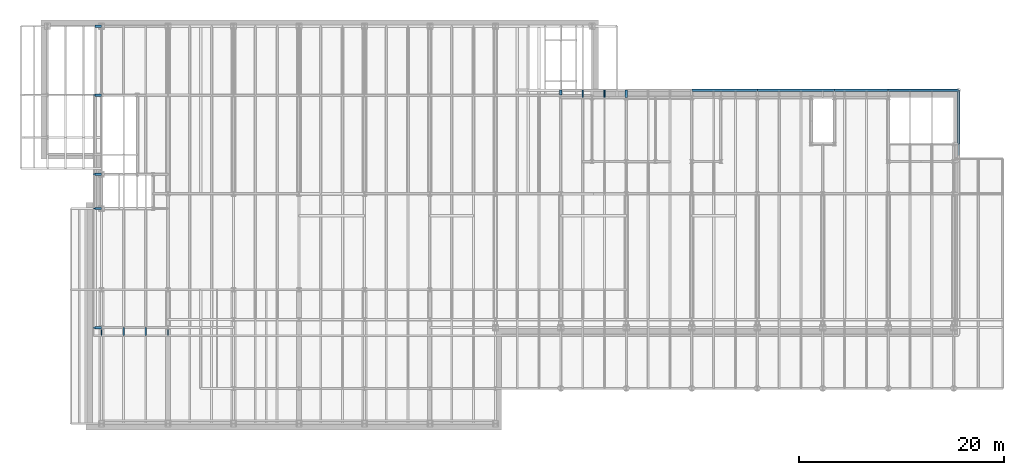
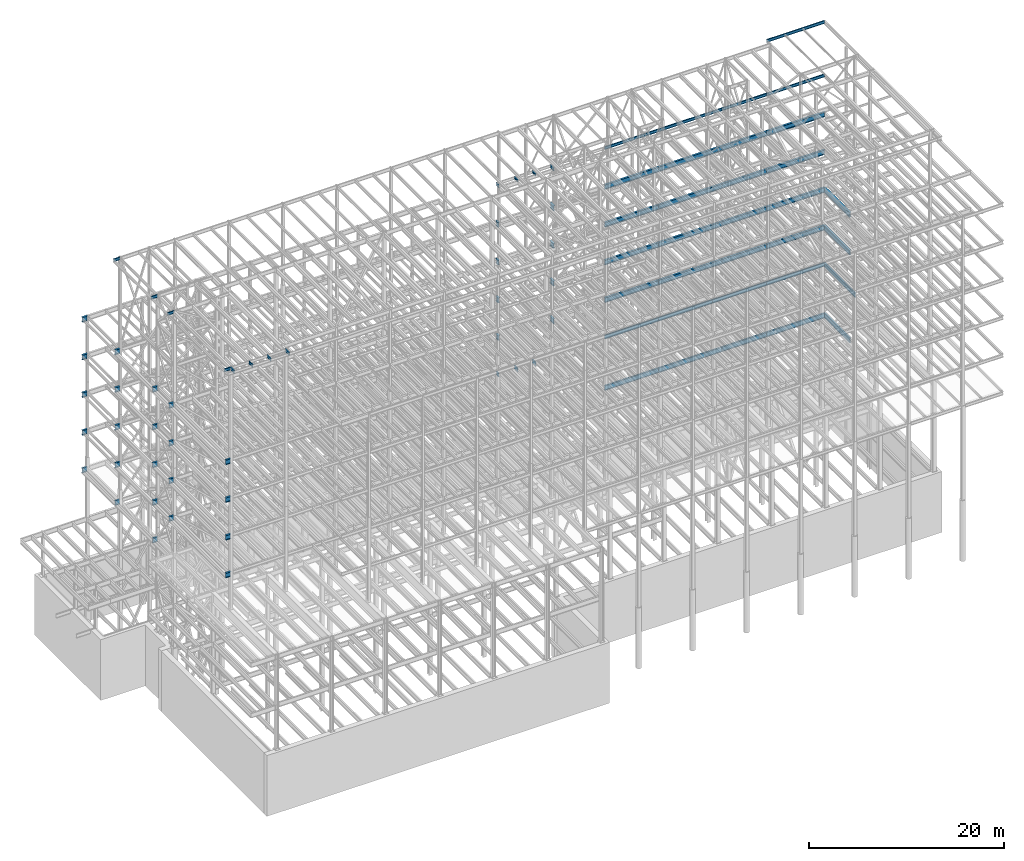
# One storey, part 148 of 150: 79 beams.
"""IFC2X3 building model written with IfcOpenShell, lengths in millimetres."""

from ifc_helpers import new_model, si_unit, frame, origin_with_axes, origin_2d_with_axis, place, context, subcontext, project, spatial, i_section, extrude, material, type_object, element, save


model = new_model("IFC2X3")

# Units and contexts
model_context = context("Model", 3, precision=1e-05, world=origin_with_axes())
body_context = subcontext(model_context, "Body", "Model", "MODEL_VIEW")
ifc_project = project(units=[si_unit("LENGTHUNIT", "METRE", prefix="MILLI"), si_unit("AREAUNIT", "SQUARE_METRE"), si_unit("VOLUMEUNIT", "CUBIC_METRE"), si_unit("MASSUNIT", "GRAM", prefix="KILO"), si_unit("TIMEUNIT", "SECOND"), si_unit("PLANEANGLEUNIT", "RADIAN"), si_unit("SOLIDANGLEUNIT", "STERADIAN"), si_unit("THERMODYNAMICTEMPERATUREUNIT", "DEGREE_CELSIUS"), si_unit("LUMINOUSINTENSITYUNIT", "LUMEN")], contexts=[model_context])

# Site, building, storey
site_placement = place(None, origin_with_axes())
site = spatial("IfcSite", under=ifc_project, at=site_placement, CompositionType="ELEMENT")
building_placement = place(site_placement, origin_with_axes())
building = spatial("IfcBuilding", under=site, at=building_placement, Name="Undefined", CompositionType="ELEMENT")
storey_placement = place(building_placement, origin_with_axes())
storey = spatial("IfcBuildingStorey", under=building, at=storey_placement, Name="Undefined", CompositionType="ELEMENT", Elevation=0.0)

# Beams
ifc_material = material(Name="STEEL/A992")
beam_type_1 = type_object("IfcBeamType", Name="W18X35", PredefinedType="NOTDEFINED")
for number, where, z_axis, x_axis, name in (
    (1, (54457.6, 31877.0, 35359.975), (0.0, 0.0, 1.0), (0.0, 1.0, 0.0), "BEAM"),
    (2, (52324.0, 31877.0, 35359.975), (0.0, 0.0, 1.0), (0.0, 1.0, 0.0), "BEAM"),
):
    element("IfcBeam", number, at=place(storey_placement, frame(where, z_axis=z_axis, x_axis=x_axis)), inside=storey, type_object=beam_type_1, material=ifc_material, Name=name, ObjectType="W18X35", context=body_context, shape_type="SweptSolid", body=[
        extrude(i_section(OverallWidth=152.4, OverallDepth=450.85, WebThickness=7.9375, FlangeThickness=10.795, FilletRadius=17.78, at=origin_2d_with_axis()), frame((736.599999999991, 0.0, 0.0), z_axis=(-1.0, 0.0, 0.0), x_axis=(0.0, -1.0, 0.0)), (0.0, 0.0, 1.0), 736.599999999991),
    ])
for number, where, z_axis, x_axis, name in (
    (3, (75793.6, 32613.6, 35359.975), (0.0, 0.0, 1.0), (1.0, 0.0, 0.0), "BEAM"),
    (4, (69392.8, 32613.6, 35359.975), (0.0, 0.0, 1.0), (1.0, 0.0, 0.0), "BEAM"),
):
    element("IfcBeam", number, at=place(storey_placement, frame(where, z_axis=z_axis, x_axis=x_axis)), inside=storey, type_object=beam_type_1, material=ifc_material, Name=name, ObjectType="W18X35", context=body_context, shape_type="SweptSolid", body=[
        extrude(i_section(OverallWidth=152.4, OverallDepth=450.85, WebThickness=7.9375, FlangeThickness=10.795, FilletRadius=17.78, at=origin_2d_with_axis()), frame((6400.80000000001, 0.0, 0.0), z_axis=(-1.0, 0.0, 0.0), x_axis=(0.0, -1.0, 0.0)), (0.0, 0.0, 1.0), 6400.8),
    ])
beam_1_placement = place(storey_placement, frame((62992.0, 32613.6, 35359.975), z_axis=(0.0, 0.0, 1.0), x_axis=(1.0, 0.0, 0.0)))
element("IfcBeam", 5, at=beam_1_placement, inside=storey, type_object=beam_type_1, material=ifc_material, Name="BEAM", ObjectType="W18X35", context=body_context, shape_type="SweptSolid", body=[
    extrude(i_section(OverallWidth=152.4, OverallDepth=450.85, WebThickness=7.9375, FlangeThickness=10.795, FilletRadius=17.78, at=origin_2d_with_axis()), frame((6400.80000000001, 0.0, 0.0), z_axis=(-1.0, 0.0, 0.0), x_axis=(0.0, -1.0, 0.0)), (0.0, 0.0, 1.0), 6400.79999999999),
])
beam_2_placement = place(storey_placement, frame((50190.4, 32131.0, 35359.975), z_axis=(0.0, 0.0, 1.0), x_axis=(0.0, 1.0, 0.0)))
element("IfcBeam", 6, at=beam_2_placement, inside=storey, type_object=beam_type_1, material=ifc_material, Name="BEAM", ObjectType="W18X35", context=body_context, shape_type="SweptSolid", body=[
    extrude(i_section(OverallWidth=152.4, OverallDepth=450.85, WebThickness=7.9375, FlangeThickness=10.795, FilletRadius=17.78, at=origin_2d_with_axis()), frame((482.600000000006, 0.0, 0.0), z_axis=(-1.0, 0.0, 0.0), x_axis=(0.0, -1.0, 0.0)), (0.0, 0.0, 1.0), 482.599999999999),
])
beam_3_placement = place(storey_placement, frame((82194.4, 32613.6, 35359.975), z_axis=(0.0, 0.0, 1.0), x_axis=(1.0, 0.0, 0.0)))
element("IfcBeam", 7, at=beam_3_placement, inside=storey, type_object=beam_type_1, material=ifc_material, Name="BEAM", ObjectType="W18X35", context=body_context, shape_type="SweptSolid", body=[
    extrude(i_section(OverallWidth=152.4, OverallDepth=450.85, WebThickness=7.9375, FlangeThickness=10.795, FilletRadius=17.78, at=origin_2d_with_axis()), frame((6883.40000000001, 0.0, 0.0), z_axis=(-1.0, 0.0, 0.0), x_axis=(0.0, -1.0, 0.0)), (0.0, 0.0, 1.0), 6883.40000000001),
])
beam_type_2 = type_object("IfcBeamType", Name="W24X68", PredefinedType="NOTDEFINED")
for number, where, z_axis, x_axis, name in (
    (8, (4673.6, 38862.0, 54181.375), (0.0, 0.0, 1.0), (1.0, 0.0, 0.0), "BEAM"),
    (9, (4673.6, 24384.0, 54181.375), (0.0, 0.0, 1.0), (1.0, 0.0, 0.0), "BEAM"),
    (10, (4673.6, 32131.0, 54181.375), (0.0, 0.0, 1.0), (1.0, 0.0, 0.0), "BEAM"),
):
    element("IfcBeam", number, at=place(storey_placement, frame(where, z_axis=z_axis, x_axis=x_axis)), inside=storey, type_object=beam_type_2, material=ifc_material, Name=name, ObjectType="W24X68", context=body_context, shape_type="SweptSolid", body=[
        extrude(i_section(OverallWidth=227.838, OverallDepth=603.25, WebThickness=11.1125, FlangeThickness=14.859, FilletRadius=23.2409, at=origin_2d_with_axis()), frame((609.599999999999, 0.0, 0.0), z_axis=(-1.0, 0.0, 0.0), x_axis=(0.0, -1.0, 0.0)), (0.0, 0.0, 1.0), 609.599999999999),
    ])
beam_4_placement = place(storey_placement, frame((50190.4, 32131.0, 54181.375), z_axis=(0.0, 0.0, 1.0), x_axis=(0.0, 1.0, 0.0)))
element("IfcBeam", 11, at=beam_4_placement, inside=storey, type_object=beam_type_2, material=ifc_material, Name="BEAM", ObjectType="W24X68", context=body_context, shape_type="SweptSolid", body=[
    extrude(i_section(OverallWidth=227.838, OverallDepth=603.25, WebThickness=11.1125, FlangeThickness=14.859, FilletRadius=23.2409, at=origin_2d_with_axis()), frame((482.600000000006, 0.0, 0.0), z_axis=(-1.0, 0.0, 0.0), x_axis=(0.0, -1.0, 0.0)), (0.0, 0.0, 1.0), 482.599999999999),
])
beam_5_placement = place(storey_placement, frame((56591.2, 31877.0, 54181.375), z_axis=(0.0, 0.0, 1.0), x_axis=(0.0, 1.0, 0.0)))
element("IfcBeam", 12, at=beam_5_placement, inside=storey, type_object=beam_type_2, material=ifc_material, Name="BEAM", ObjectType="W24X68", context=body_context, shape_type="SweptSolid", body=[
    extrude(i_section(OverallWidth=227.838, OverallDepth=603.25, WebThickness=11.1125, FlangeThickness=14.859, FilletRadius=23.2409, at=origin_2d_with_axis()), frame((736.599999999991, 0.0, 0.0), z_axis=(-1.0, 0.0, 0.0), x_axis=(0.0, -1.0, 0.0)), (0.0, 0.0, 1.0), 736.599999999991),
])
beam_6_placement = place(storey_placement, frame((62992.0, 32613.6, 54181.375), z_axis=(0.0, 0.0, 1.0), x_axis=(1.0, 0.0, 0.0)))
element("IfcBeam", 13, at=beam_6_placement, inside=storey, type_object=beam_type_2, material=ifc_material, Name="BEAM", ObjectType="W24X68", context=body_context, shape_type="SweptSolid", body=[
    extrude(i_section(OverallWidth=227.838, OverallDepth=603.25, WebThickness=11.1125, FlangeThickness=14.859, FilletRadius=23.2409, at=origin_2d_with_axis()), frame((6400.79935992001, 0.0, 0.0), z_axis=(-1.0, 0.0, 0.0), x_axis=(0.0, -1.0, 0.0)), (0.0, 0.0, 1.0), 6400.79935991999),
])
beam_7_placement = place(storey_placement, frame((69392.8, 32613.6, 54181.375), z_axis=(0.0, 0.0, 1.0), x_axis=(1.0, 0.0, 0.0)))
element("IfcBeam", 14, at=beam_7_placement, inside=storey, type_object=beam_type_2, material=ifc_material, Name="BEAM", ObjectType="W24X68", context=body_context, shape_type="SweptSolid", body=[
    extrude(i_section(OverallWidth=227.838, OverallDepth=603.25, WebThickness=11.1125, FlangeThickness=14.859, FilletRadius=23.2409, at=origin_2d_with_axis()), frame((7531.10000000001, 0.0, 0.0), z_axis=(-1.0, 0.0, 0.0), x_axis=(0.0, -1.0, 0.0)), (0.0, 0.0, 1.0), 7531.10000000001),
])
beam_8_placement = place(storey_placement, frame((82194.4, 32613.6, 54181.375), z_axis=(0.0, 0.0, 1.0), x_axis=(1.0, 0.0, 0.0)))
element("IfcBeam", 15, at=beam_8_placement, inside=storey, type_object=beam_type_2, material=ifc_material, Name="BEAM", ObjectType="W24X68", context=body_context, shape_type="SweptSolid", body=[
    extrude(i_section(OverallWidth=227.838, OverallDepth=603.25, WebThickness=11.1125, FlangeThickness=14.859, FilletRadius=23.2409, at=origin_2d_with_axis()), frame((6883.40000000001, 0.0, 0.0), z_axis=(-1.0, 0.0, 0.0), x_axis=(0.0, -1.0, 0.0)), (0.0, 0.0, 1.0), 6883.40000000001),
])
beam_9_placement = place(storey_placement, frame((76923.9, 32613.6, 54181.375), z_axis=(0.0, 0.0, 1.0), x_axis=(1.0, 0.0, 0.0)))
element("IfcBeam", 16, at=beam_9_placement, inside=storey, type_object=beam_type_2, material=ifc_material, Name="BEAM", ObjectType="W24X68", context=body_context, shape_type="SweptSolid", body=[
    extrude(i_section(OverallWidth=227.838, OverallDepth=603.25, WebThickness=11.1125, FlangeThickness=14.859, FilletRadius=23.2409, at=origin_2d_with_axis()), frame((5270.5, 0.0, 0.0), z_axis=(-1.0, 0.0, 0.0), x_axis=(0.0, -1.0, 0.0)), (0.0, 0.0, 1.0), 5270.5),
])
for number, where, z_axis, x_axis, name in (
    (17, (4673.6, 9398.0, 54181.375), (0.0, 0.0, 1.0), (1.0, 0.0, 0.0), "BEAM"),
    (18, (4673.6, 21043.9, 54181.375), (0.0, 0.0, 1.0), (1.0, 0.0, 0.0), "BEAM"),
    (19, (4673.6, 38862.0, 49456.975), (0.0, 0.0, 1.0), (1.0, 0.0, 0.0), "BEAM"),
    (20, (4673.6, 24384.0, 49456.975), (0.0, 0.0, 1.0), (1.0, 0.0, 0.0), "BEAM"),
    (21, (4673.6, 32131.0, 49456.975), (0.0, 0.0, 1.0), (1.0, 0.0, 0.0), "BEAM"),
):
    element("IfcBeam", number, at=place(storey_placement, frame(where, z_axis=z_axis, x_axis=x_axis)), inside=storey, type_object=beam_type_2, material=ifc_material, Name=name, ObjectType="W24X68", context=body_context, shape_type="SweptSolid", body=[
        extrude(i_section(OverallWidth=227.838, OverallDepth=603.25, WebThickness=11.1125, FlangeThickness=14.859, FilletRadius=23.2409, at=origin_2d_with_axis()), frame((609.599999999999, 0.0, 0.0), z_axis=(-1.0, 0.0, 0.0), x_axis=(0.0, -1.0, 0.0)), (0.0, 0.0, 1.0), 609.599999999999),
    ])
beam_10_placement = place(storey_placement, frame((50190.4, 32131.0, 49456.975), z_axis=(0.0, 0.0, 1.0), x_axis=(0.0, 1.0, 0.0)))
element("IfcBeam", 22, at=beam_10_placement, inside=storey, type_object=beam_type_2, material=ifc_material, Name="BEAM", ObjectType="W24X68", context=body_context, shape_type="SweptSolid", body=[
    extrude(i_section(OverallWidth=227.838, OverallDepth=603.25, WebThickness=11.1125, FlangeThickness=14.859, FilletRadius=23.2409, at=origin_2d_with_axis()), frame((482.600000000006, 0.0, 0.0), z_axis=(-1.0, 0.0, 0.0), x_axis=(0.0, -1.0, 0.0)), (0.0, 0.0, 1.0), 482.599999999999),
])
beam_11_placement = place(storey_placement, frame((56591.2, 31877.0, 49456.975), z_axis=(0.0, 0.0, 1.0), x_axis=(0.0, 1.0, 0.0)))
element("IfcBeam", 23, at=beam_11_placement, inside=storey, type_object=beam_type_2, material=ifc_material, Name="BEAM", ObjectType="W24X68", context=body_context, shape_type="SweptSolid", body=[
    extrude(i_section(OverallWidth=227.838, OverallDepth=603.25, WebThickness=11.1125, FlangeThickness=14.859, FilletRadius=23.2409, at=origin_2d_with_axis()), frame((736.599999999991, 0.0, 0.0), z_axis=(-1.0, 0.0, 0.0), x_axis=(0.0, -1.0, 0.0)), (0.0, 0.0, 1.0), 736.599999999991),
])
beam_12_placement = place(storey_placement, frame((62992.0, 32613.6, 49456.975), z_axis=(0.0, 0.0, 1.0), x_axis=(1.0, 0.0, 0.0)))
element("IfcBeam", 24, at=beam_12_placement, inside=storey, type_object=beam_type_2, material=ifc_material, Name="BEAM", ObjectType="W24X68", context=body_context, shape_type="SweptSolid", body=[
    extrude(i_section(OverallWidth=227.838, OverallDepth=603.25, WebThickness=11.1125, FlangeThickness=14.859, FilletRadius=23.2409, at=origin_2d_with_axis()), frame((6400.79935992001, 0.0, 0.0), z_axis=(-1.0, 0.0, 0.0), x_axis=(0.0, -1.0, 0.0)), (0.0, 0.0, 1.0), 6400.79935991999),
])
beam_13_placement = place(storey_placement, frame((69392.8, 32613.6, 49456.975), z_axis=(0.0, 0.0, 1.0), x_axis=(1.0, 0.0, 0.0)))
element("IfcBeam", 25, at=beam_13_placement, inside=storey, type_object=beam_type_2, material=ifc_material, Name="BEAM", ObjectType="W24X68", context=body_context, shape_type="SweptSolid", body=[
    extrude(i_section(OverallWidth=227.838, OverallDepth=603.25, WebThickness=11.1125, FlangeThickness=14.859, FilletRadius=23.2409, at=origin_2d_with_axis()), frame((7531.10000000001, 0.0, 0.0), z_axis=(-1.0, 0.0, 0.0), x_axis=(0.0, -1.0, 0.0)), (0.0, 0.0, 1.0), 7531.10000000001),
])
beam_14_placement = place(storey_placement, frame((82194.4, 32613.6, 49456.975), z_axis=(0.0, 0.0, 1.0), x_axis=(1.0, 0.0, 0.0)))
element("IfcBeam", 26, at=beam_14_placement, inside=storey, type_object=beam_type_2, material=ifc_material, Name="BEAM", ObjectType="W24X68", context=body_context, shape_type="SweptSolid", body=[
    extrude(i_section(OverallWidth=227.838, OverallDepth=603.25, WebThickness=11.1125, FlangeThickness=14.859, FilletRadius=23.2409, at=origin_2d_with_axis()), frame((6883.40000000001, 0.0, 0.0), z_axis=(-1.0, 0.0, 0.0), x_axis=(0.0, -1.0, 0.0)), (0.0, 0.0, 1.0), 6883.40000000001),
])
beam_15_placement = place(storey_placement, frame((76923.9, 32613.6, 49456.975), z_axis=(0.0, 0.0, 1.0), x_axis=(1.0, 0.0, 0.0)))
element("IfcBeam", 27, at=beam_15_placement, inside=storey, type_object=beam_type_2, material=ifc_material, Name="BEAM", ObjectType="W24X68", context=body_context, shape_type="SweptSolid", body=[
    extrude(i_section(OverallWidth=227.838, OverallDepth=603.25, WebThickness=11.1125, FlangeThickness=14.859, FilletRadius=23.2409, at=origin_2d_with_axis()), frame((5270.5, 0.0, 0.0), z_axis=(-1.0, 0.0, 0.0), x_axis=(0.0, -1.0, 0.0)), (0.0, 0.0, 1.0), 5270.5),
])
for number, where, z_axis, x_axis, name in (
    (28, (4673.6, 9398.0, 49456.975), (0.0, 0.0, 1.0), (1.0, 0.0, 0.0), "BEAM"),
    (29, (4673.6, 21043.9, 49456.975), (0.0, 0.0, 1.0), (1.0, 0.0, 0.0), "BEAM"),
    (30, (4673.6, 38862.0, 44732.575), (0.0, 0.0, 1.0), (1.0, 0.0, 0.0), "BEAM"),
    (31, (4673.6, 24384.0, 44732.575), (0.0, 0.0, 1.0), (1.0, 0.0, 0.0), "BEAM"),
    (32, (4673.6, 32131.0, 44732.575), (0.0, 0.0, 1.0), (1.0, 0.0, 0.0), "BEAM"),
):
    element("IfcBeam", number, at=place(storey_placement, frame(where, z_axis=z_axis, x_axis=x_axis)), inside=storey, type_object=beam_type_2, material=ifc_material, Name=name, ObjectType="W24X68", context=body_context, shape_type="SweptSolid", body=[
        extrude(i_section(OverallWidth=227.838, OverallDepth=603.25, WebThickness=11.1125, FlangeThickness=14.859, FilletRadius=23.2409, at=origin_2d_with_axis()), frame((609.599999999999, 0.0, 0.0), z_axis=(-1.0, 0.0, 0.0), x_axis=(0.0, -1.0, 0.0)), (0.0, 0.0, 1.0), 609.599999999999),
    ])
beam_16_placement = place(storey_placement, frame((50190.4, 32131.0, 44732.575), z_axis=(0.0, 0.0, 1.0), x_axis=(0.0, 1.0, 0.0)))
element("IfcBeam", 33, at=beam_16_placement, inside=storey, type_object=beam_type_2, material=ifc_material, Name="BEAM", ObjectType="W24X68", context=body_context, shape_type="SweptSolid", body=[
    extrude(i_section(OverallWidth=227.838, OverallDepth=603.25, WebThickness=11.1125, FlangeThickness=14.859, FilletRadius=23.2409, at=origin_2d_with_axis()), frame((482.600000000006, 0.0, 0.0), z_axis=(-1.0, 0.0, 0.0), x_axis=(0.0, -1.0, 0.0)), (0.0, 0.0, 1.0), 482.599999999999),
])
beam_17_placement = place(storey_placement, frame((56591.2, 31877.0, 44732.575), z_axis=(0.0, 0.0, 1.0), x_axis=(0.0, 1.0, 0.0)))
element("IfcBeam", 34, at=beam_17_placement, inside=storey, type_object=beam_type_2, material=ifc_material, Name="BEAM", ObjectType="W24X68", context=body_context, shape_type="SweptSolid", body=[
    extrude(i_section(OverallWidth=227.838, OverallDepth=603.25, WebThickness=11.1125, FlangeThickness=14.859, FilletRadius=23.2409, at=origin_2d_with_axis()), frame((736.599999999991, 0.0, 0.0), z_axis=(-1.0, 0.0, 0.0), x_axis=(0.0, -1.0, 0.0)), (0.0, 0.0, 1.0), 736.599999999991),
])
beam_18_placement = place(storey_placement, frame((62992.0, 32613.6, 44732.575), z_axis=(0.0, 0.0, 1.0), x_axis=(1.0, 0.0, 0.0)))
element("IfcBeam", 35, at=beam_18_placement, inside=storey, type_object=beam_type_2, material=ifc_material, Name="BEAM", ObjectType="W24X68", context=body_context, shape_type="SweptSolid", body=[
    extrude(i_section(OverallWidth=227.838, OverallDepth=603.25, WebThickness=11.1125, FlangeThickness=14.859, FilletRadius=23.2409, at=origin_2d_with_axis()), frame((6400.79935992001, 0.0, 0.0), z_axis=(-1.0, 0.0, 0.0), x_axis=(0.0, -1.0, 0.0)), (0.0, 0.0, 1.0), 6400.79935991999),
])
beam_19_placement = place(storey_placement, frame((69392.8, 32613.6, 44732.575), z_axis=(0.0, 0.0, 1.0), x_axis=(1.0, 0.0, 0.0)))
element("IfcBeam", 36, at=beam_19_placement, inside=storey, type_object=beam_type_2, material=ifc_material, Name="BEAM", ObjectType="W24X68", context=body_context, shape_type="SweptSolid", body=[
    extrude(i_section(OverallWidth=227.838, OverallDepth=603.25, WebThickness=11.1125, FlangeThickness=14.859, FilletRadius=23.2409, at=origin_2d_with_axis()), frame((7531.10000000001, 0.0, 0.0), z_axis=(-1.0, 0.0, 0.0), x_axis=(0.0, -1.0, 0.0)), (0.0, 0.0, 1.0), 7531.10000000001),
])
beam_20_placement = place(storey_placement, frame((82194.4, 32613.6, 44732.575), z_axis=(0.0, 0.0, 1.0), x_axis=(1.0, 0.0, 0.0)))
element("IfcBeam", 37, at=beam_20_placement, inside=storey, type_object=beam_type_2, material=ifc_material, Name="BEAM", ObjectType="W24X68", context=body_context, shape_type="SweptSolid", body=[
    extrude(i_section(OverallWidth=227.838, OverallDepth=603.25, WebThickness=11.1125, FlangeThickness=14.859, FilletRadius=23.2409, at=origin_2d_with_axis()), frame((6883.40000000001, 0.0, 0.0), z_axis=(-1.0, 0.0, 0.0), x_axis=(0.0, -1.0, 0.0)), (0.0, 0.0, 1.0), 6883.40000000001),
])
beam_21_placement = place(storey_placement, frame((76923.9, 32613.6, 44732.575), z_axis=(0.0, 0.0, 1.0), x_axis=(1.0, 0.0, 0.0)))
element("IfcBeam", 38, at=beam_21_placement, inside=storey, type_object=beam_type_2, material=ifc_material, Name="BEAM", ObjectType="W24X68", context=body_context, shape_type="SweptSolid", body=[
    extrude(i_section(OverallWidth=227.838, OverallDepth=603.25, WebThickness=11.1125, FlangeThickness=14.859, FilletRadius=23.2409, at=origin_2d_with_axis()), frame((5270.5, 0.0, 0.0), z_axis=(-1.0, 0.0, 0.0), x_axis=(0.0, -1.0, 0.0)), (0.0, 0.0, 1.0), 5270.5),
])
beam_22_placement = place(storey_placement, frame((89077.8, 27355.8, 44732.575), z_axis=(0.0, 0.0, 1.0), x_axis=(0.0, 1.0, 0.0)))
element("IfcBeam", 39, at=beam_22_placement, inside=storey, type_object=beam_type_2, material=ifc_material, Name="BEAM", ObjectType="W24X68", context=body_context, shape_type="SweptSolid", body=[
    extrude(i_section(OverallWidth=227.838, OverallDepth=603.25, WebThickness=11.1125, FlangeThickness=14.859, FilletRadius=23.2409, at=origin_2d_with_axis()), frame((5257.8, 0.0, 0.0), z_axis=(-1.0, 0.0, 0.0), x_axis=(0.0, -1.0, 0.0)), (0.0, 0.0, 1.0), 5257.8),
])
for number, where, z_axis, x_axis, name in (
    (40, (4673.6, 9398.0, 44732.575), (0.0, 0.0, 1.0), (1.0, 0.0, 0.0), "BEAM"),
    (41, (4673.6, 21043.9, 44732.575), (0.0, 0.0, 1.0), (1.0, 0.0, 0.0), "BEAM"),
    (42, (4673.6, 38862.0, 40008.175), (0.0, 0.0, 1.0), (1.0, 0.0, 0.0), "BEAM"),
    (43, (4673.6, 24384.0, 40008.175), (0.0, 0.0, 1.0), (1.0, 0.0, 0.0), "BEAM"),
    (44, (4673.6, 32131.0, 40008.175), (0.0, 0.0, 1.0), (1.0, 0.0, 0.0), "BEAM"),
):
    element("IfcBeam", number, at=place(storey_placement, frame(where, z_axis=z_axis, x_axis=x_axis)), inside=storey, type_object=beam_type_2, material=ifc_material, Name=name, ObjectType="W24X68", context=body_context, shape_type="SweptSolid", body=[
        extrude(i_section(OverallWidth=227.838, OverallDepth=603.25, WebThickness=11.1125, FlangeThickness=14.859, FilletRadius=23.2409, at=origin_2d_with_axis()), frame((609.599999999999, 0.0, 0.0), z_axis=(-1.0, 0.0, 0.0), x_axis=(0.0, -1.0, 0.0)), (0.0, 0.0, 1.0), 609.599999999999),
    ])
beam_23_placement = place(storey_placement, frame((50190.4, 32131.0, 40008.175), z_axis=(0.0, 0.0, 1.0), x_axis=(0.0, 1.0, 0.0)))
element("IfcBeam", 45, at=beam_23_placement, inside=storey, type_object=beam_type_2, material=ifc_material, Name="BEAM", ObjectType="W24X68", context=body_context, shape_type="SweptSolid", body=[
    extrude(i_section(OverallWidth=227.838, OverallDepth=603.25, WebThickness=11.1125, FlangeThickness=14.859, FilletRadius=23.2409, at=origin_2d_with_axis()), frame((482.600000000006, 0.0, 0.0), z_axis=(-1.0, 0.0, 0.0), x_axis=(0.0, -1.0, 0.0)), (0.0, 0.0, 1.0), 482.599999999999),
])
beam_24_placement = place(storey_placement, frame((56591.2, 31877.0, 40008.175), z_axis=(0.0, 0.0, 1.0), x_axis=(0.0, 1.0, 0.0)))
element("IfcBeam", 46, at=beam_24_placement, inside=storey, type_object=beam_type_2, material=ifc_material, Name="BEAM", ObjectType="W24X68", context=body_context, shape_type="SweptSolid", body=[
    extrude(i_section(OverallWidth=227.838, OverallDepth=603.25, WebThickness=11.1125, FlangeThickness=14.859, FilletRadius=23.2409, at=origin_2d_with_axis()), frame((736.599999999991, 0.0, 0.0), z_axis=(-1.0, 0.0, 0.0), x_axis=(0.0, -1.0, 0.0)), (0.0, 0.0, 1.0), 736.599999999991),
])
beam_25_placement = place(storey_placement, frame((62992.0, 32613.6, 40008.175), z_axis=(0.0, 0.0, 1.0), x_axis=(1.0, 0.0, 0.0)))
element("IfcBeam", 47, at=beam_25_placement, inside=storey, type_object=beam_type_2, material=ifc_material, Name="BEAM", ObjectType="W24X68", context=body_context, shape_type="SweptSolid", body=[
    extrude(i_section(OverallWidth=227.838, OverallDepth=603.25, WebThickness=11.1125, FlangeThickness=14.859, FilletRadius=23.2409, at=origin_2d_with_axis()), frame((6400.80000000001, 0.0, 0.0), z_axis=(-1.0, 0.0, 0.0), x_axis=(0.0, -1.0, 0.0)), (0.0, 0.0, 1.0), 6400.8),
])
beam_26_placement = place(storey_placement, frame((69392.8, 32613.6, 40008.175), z_axis=(0.0, 0.0, 1.0), x_axis=(1.0, 0.0, 0.0)))
element("IfcBeam", 48, at=beam_26_placement, inside=storey, type_object=beam_type_2, material=ifc_material, Name="BEAM", ObjectType="W24X68", context=body_context, shape_type="SweptSolid", body=[
    extrude(i_section(OverallWidth=227.838, OverallDepth=603.25, WebThickness=11.1125, FlangeThickness=14.859, FilletRadius=23.2409, at=origin_2d_with_axis()), frame((7531.10000000001, 0.0, 0.0), z_axis=(-1.0, 0.0, 0.0), x_axis=(0.0, -1.0, 0.0)), (0.0, 0.0, 1.0), 7531.10000000001),
])
beam_27_placement = place(storey_placement, frame((82194.4, 32613.6, 40008.175), z_axis=(0.0, 0.0, 1.0), x_axis=(1.0, 0.0, 0.0)))
element("IfcBeam", 49, at=beam_27_placement, inside=storey, type_object=beam_type_2, material=ifc_material, Name="BEAM", ObjectType="W24X68", context=body_context, shape_type="SweptSolid", body=[
    extrude(i_section(OverallWidth=227.838, OverallDepth=603.25, WebThickness=11.1125, FlangeThickness=14.859, FilletRadius=23.2409, at=origin_2d_with_axis()), frame((6883.40000000001, 0.0, 0.0), z_axis=(-1.0, 0.0, 0.0), x_axis=(0.0, -1.0, 0.0)), (0.0, 0.0, 1.0), 6883.40000000001),
])
beam_28_placement = place(storey_placement, frame((76923.9, 32613.6, 40008.175), z_axis=(0.0, 0.0, 1.0), x_axis=(1.0, 0.0, 0.0)))
element("IfcBeam", 50, at=beam_28_placement, inside=storey, type_object=beam_type_2, material=ifc_material, Name="BEAM", ObjectType="W24X68", context=body_context, shape_type="SweptSolid", body=[
    extrude(i_section(OverallWidth=227.838, OverallDepth=603.25, WebThickness=11.1125, FlangeThickness=14.859, FilletRadius=23.2409, at=origin_2d_with_axis()), frame((5270.5, 0.0, 0.0), z_axis=(-1.0, 0.0, 0.0), x_axis=(0.0, -1.0, 0.0)), (0.0, 0.0, 1.0), 5270.5),
])
beam_29_placement = place(storey_placement, frame((89077.8, 27355.8, 40008.175), z_axis=(0.0, 0.0, 1.0), x_axis=(0.0, 1.0, 0.0)))
element("IfcBeam", 51, at=beam_29_placement, inside=storey, type_object=beam_type_2, material=ifc_material, Name="BEAM", ObjectType="W24X68", context=body_context, shape_type="SweptSolid", body=[
    extrude(i_section(OverallWidth=227.838, OverallDepth=603.25, WebThickness=11.1125, FlangeThickness=14.859, FilletRadius=23.2409, at=origin_2d_with_axis()), frame((5257.8, 0.0, 0.0), z_axis=(-1.0, 0.0, 0.0), x_axis=(0.0, -1.0, 0.0)), (0.0, 0.0, 1.0), 5257.8),
])
for number, where, z_axis, x_axis, name in (
    (52, (4673.6, 9398.0, 40008.175), (0.0, 0.0, 1.0), (1.0, 0.0, 0.0), "BEAM"),
    (53, (4673.6, 21043.9, 40008.175), (0.0, 0.0, 1.0), (1.0, 0.0, 0.0), "BEAM"),
):
    element("IfcBeam", number, at=place(storey_placement, frame(where, z_axis=z_axis, x_axis=x_axis)), inside=storey, type_object=beam_type_2, material=ifc_material, Name=name, ObjectType="W24X68", context=body_context, shape_type="SweptSolid", body=[
        extrude(i_section(OverallWidth=227.838, OverallDepth=603.25, WebThickness=11.1125, FlangeThickness=14.859, FilletRadius=23.2409, at=origin_2d_with_axis()), frame((609.599999999999, 0.0, 0.0), z_axis=(-1.0, 0.0, 0.0), x_axis=(0.0, -1.0, 0.0)), (0.0, 0.0, 1.0), 609.599999999999),
    ])
beam_type_3 = type_object("IfcBeamType", Name="W14X22", PredefinedType="NOTDEFINED")
for number, where, z_axis, x_axis, name in (
    (54, (5283.2, 32131.0, 65738.375), (0.0, 0.0, 1.0), (-1.0, 0.0, 0.0), "BEAM"),
    (55, (5283.2, 24384.0, 65738.375), (0.0, 0.0, 1.0), (-1.0, 0.0, 0.0), "BEAM"),
    (56, (5283.2, 21043.9, 65738.375), (0.0, 0.0, 1.0), (-1.0, 0.0, 0.0), "BEAM"),
    (57, (5283.2, 9398.0, 65738.375), (0.0, 0.0, 1.0), (-1.0, 0.0, 0.0), "BEAM"),
    (58, (9618.13333333333, 8610.6, 65738.375), (0.0, 0.0, 1.0), (0.0, 1.0, 0.0), "BEAM"),
    (59, (7450.66666666667, 8610.6, 65738.375), (0.0, 0.0, 1.0), (0.0, 1.0, 0.0), "BEAM"),
    (60, (5283.2, 9398.0, 65738.375), (0.0, 0.0, 1.0), (0.0, -1.0, 0.0), "BEAM"),
    (61, (11785.6, 9398.0, 65738.375), (0.0, 0.0, 1.0), (0.0, -1.0, 0.0), "BEAM"),
):
    element("IfcBeam", number, at=place(storey_placement, frame(where, z_axis=z_axis, x_axis=x_axis)), inside=storey, type_object=beam_type_3, material=ifc_material, Name=name, ObjectType="W14X22", context=body_context, shape_type="SweptSolid", body=[
        extrude(i_section(OverallWidth=127.0, OverallDepth=349.25, WebThickness=6.3499, FlangeThickness=8.509, FilletRadius=18.4785, at=origin_2d_with_axis()), frame((787.400000000001, 0.0, 0.0), z_axis=(-1.0, 0.0, 0.0), x_axis=(0.0, -1.0, 0.0)), (0.0, 0.0, 1.0), 787.400000000001),
    ])
beam_30_placement = place(storey_placement, frame((82194.4, 32613.6, 65738.375), z_axis=(0.0, 0.0, 1.0), x_axis=(1.0, 0.0, 0.0)))
element("IfcBeam", 62, at=beam_30_placement, inside=storey, type_object=beam_type_3, material=ifc_material, Name="BEAM", ObjectType="W14X22", context=body_context, shape_type="SweptSolid", body=[
    extrude(i_section(OverallWidth=127.0, OverallDepth=349.25, WebThickness=6.3499, FlangeThickness=8.509, FilletRadius=18.4785, at=origin_2d_with_axis()), frame((6883.40000000001, 0.0, 0.0), z_axis=(-1.0, 0.0, 0.0), x_axis=(0.0, -1.0, 0.0)), (0.0, 0.0, 1.0), 6883.40000000001),
])
beam_31_placement = place(storey_placement, frame((76923.9, 32613.6, 59032.775), z_axis=(0.0, 0.0, 1.0), x_axis=(1.0, 0.0, 0.0)))
element("IfcBeam", 63, at=beam_31_placement, inside=storey, type_object=beam_type_3, material=ifc_material, Name="BEAM", ObjectType="W14X22", context=body_context, shape_type="SweptSolid", body=[
    extrude(i_section(OverallWidth=127.0, OverallDepth=349.25, WebThickness=6.3499, FlangeThickness=8.509, FilletRadius=18.4785, at=origin_2d_with_axis()), frame((5270.5, 0.0, 0.0), z_axis=(-1.0, 0.0, 0.0), x_axis=(0.0, -1.0, 0.0)), (0.0, 0.0, 1.0), 5270.5),
])
beam_32_placement = place(storey_placement, frame((69392.8, 32613.6, 59032.775), z_axis=(0.0, 0.0, 1.0), x_axis=(1.0, 0.0, 0.0)))
element("IfcBeam", 64, at=beam_32_placement, inside=storey, type_object=beam_type_3, material=ifc_material, Name="BEAM", ObjectType="W14X22", context=body_context, shape_type="SweptSolid", body=[
    extrude(i_section(OverallWidth=127.0, OverallDepth=349.25, WebThickness=6.3499, FlangeThickness=8.509, FilletRadius=18.4785, at=origin_2d_with_axis()), frame((7531.10000000001, 0.0, 0.0), z_axis=(-1.0, 0.0, 0.0), x_axis=(0.0, -1.0, 0.0)), (0.0, 0.0, 1.0), 7531.10000000001),
])
beam_33_placement = place(storey_placement, frame((62992.0, 32613.6, 59032.775), z_axis=(0.0, 0.0, 1.0), x_axis=(1.0, 0.0, 0.0)))
element("IfcBeam", 65, at=beam_33_placement, inside=storey, type_object=beam_type_3, material=ifc_material, Name="BEAM", ObjectType="W14X22", context=body_context, shape_type="SweptSolid", body=[
    extrude(i_section(OverallWidth=127.0, OverallDepth=349.25, WebThickness=6.3499, FlangeThickness=8.509, FilletRadius=18.4785, at=origin_2d_with_axis()), frame((6400.80000000001, 0.0, 0.0), z_axis=(-1.0, 0.0, 0.0), x_axis=(0.0, -1.0, 0.0)), (0.0, 0.0, 1.0), 6400.79999999999),
])
beam_34_placement = place(storey_placement, frame((50190.4, 32131.0, 59032.775), z_axis=(0.0, 0.0, 1.0), x_axis=(0.0, 1.0, 0.0)))
element("IfcBeam", 66, at=beam_34_placement, inside=storey, type_object=beam_type_3, material=ifc_material, Name="BEAM", ObjectType="W14X22", context=body_context, shape_type="SweptSolid", body=[
    extrude(i_section(OverallWidth=127.0, OverallDepth=349.25, WebThickness=6.3499, FlangeThickness=8.509, FilletRadius=18.4785, at=origin_2d_with_axis()), frame((482.600073659989, 0.0, 0.0), z_axis=(-1.0, 0.0, 0.0), x_axis=(0.0, -1.0, 0.0)), (0.0, 0.0, 1.0), 482.600073659989),
])
beam_35_placement = place(storey_placement, frame((56591.2, 31877.0, 59032.775), z_axis=(0.0, 0.0, 1.0), x_axis=(0.0, 1.0, 0.0)))
element("IfcBeam", 67, at=beam_35_placement, inside=storey, type_object=beam_type_3, material=ifc_material, Name="BEAM", ObjectType="W14X22", context=body_context, shape_type="SweptSolid", body=[
    extrude(i_section(OverallWidth=127.0, OverallDepth=349.25, WebThickness=6.3499, FlangeThickness=8.509, FilletRadius=18.4785, at=origin_2d_with_axis()), frame((736.599999999991, 0.0, 0.0), z_axis=(-1.0, 0.0, 0.0), x_axis=(0.0, -1.0, 0.0)), (0.0, 0.0, 1.0), 736.599999999991),
])
beam_36_placement = place(storey_placement, frame((82194.4, 32613.6, 59032.775), z_axis=(0.0, 0.0, 1.0), x_axis=(1.0, 0.0, 0.0)))
element("IfcBeam", 68, at=beam_36_placement, inside=storey, type_object=beam_type_3, material=ifc_material, Name="BEAM", ObjectType="W14X22", context=body_context, shape_type="SweptSolid", body=[
    extrude(i_section(OverallWidth=127.0, OverallDepth=349.25, WebThickness=6.3499, FlangeThickness=8.509, FilletRadius=18.4785, at=origin_2d_with_axis()), frame((6883.40000000001, 0.0, 0.0), z_axis=(-1.0, 0.0, 0.0), x_axis=(0.0, -1.0, 0.0)), (0.0, 0.0, 1.0), 6883.40000000001),
])
beam_type_4 = type_object("IfcBeamType", Name="W10X15", PredefinedType="NOTDEFINED")
for number, where, z_axis, x_axis, name in (
    (69, (52324.0, 31877.0, 59080.4), (0.0, 0.0, 1.0), (0.0, 1.0, 0.0), "BEAM"),
    (70, (54457.6, 31877.0, 59080.4), (0.0, 0.0, 1.0), (0.0, 1.0, 0.0), "BEAM"),
):
    element("IfcBeam", number, at=place(storey_placement, frame(where, z_axis=z_axis, x_axis=x_axis)), inside=storey, type_object=beam_type_4, material=ifc_material, Name=name, ObjectType="W10X15", context=body_context, shape_type="SweptSolid", body=[
        extrude(i_section(OverallWidth=101.6, OverallDepth=254.0, WebThickness=6.3499, FlangeThickness=6.858, FilletRadius=13.7795, at=origin_2d_with_axis()), frame((736.599999999991, 0.0, 0.0), z_axis=(-1.0, 0.0, 0.0), x_axis=(0.0, -1.0, 0.0)), (0.0, 0.0, 1.0), 736.599999999991),
    ])
beam_type_5 = type_object("IfcBeamType", Name="W24X55", PredefinedType="NOTDEFINED")
beam_37_placement = place(storey_placement, frame((89077.8, 27355.8, 28986.1625), z_axis=(0.0, 0.0, 1.0), x_axis=(0.0, 1.0, 0.0)))
element("IfcBeam", 71, at=beam_37_placement, inside=storey, type_object=beam_type_5, material=ifc_material, Name="BEAM", ObjectType="W24X55", context=body_context, shape_type="SweptSolid", body=[
    extrude(i_section(OverallWidth=178.054, OverallDepth=600.075, WebThickness=9.5249, FlangeThickness=12.827, FilletRadius=23.6854, at=origin_2d_with_axis()), frame((5257.8, 0.0, 0.0), z_axis=(-1.0, 0.0, 0.0), x_axis=(0.0, -1.0, 0.0)), (0.0, 0.0, 1.0), 5257.8),
])
beam_38_placement = place(storey_placement, frame((82194.4, 32613.6, 28986.1625), z_axis=(0.0, 0.0, 1.0), x_axis=(1.0, 0.0, 0.0)))
element("IfcBeam", 72, at=beam_38_placement, inside=storey, type_object=beam_type_5, material=ifc_material, Name="BEAM", ObjectType="W24X55", context=body_context, shape_type="SweptSolid", body=[
    extrude(i_section(OverallWidth=178.054, OverallDepth=600.075, WebThickness=9.5249, FlangeThickness=12.827, FilletRadius=23.6854, at=origin_2d_with_axis()), frame((6883.40000000001, 0.0, 0.0), z_axis=(-1.0, 0.0, 0.0), x_axis=(0.0, -1.0, 0.0)), (0.0, 0.0, 1.0), 6883.40000000001),
])
beam_39_placement = place(storey_placement, frame((76923.9, 32613.6, 28986.1625), z_axis=(0.0, 0.0, 1.0), x_axis=(1.0, 0.0, 0.0)))
element("IfcBeam", 73, at=beam_39_placement, inside=storey, type_object=beam_type_5, material=ifc_material, Name="BEAM", ObjectType="W24X55", context=body_context, shape_type="SweptSolid", body=[
    extrude(i_section(OverallWidth=178.054, OverallDepth=600.075, WebThickness=9.5249, FlangeThickness=12.827, FilletRadius=23.6854, at=origin_2d_with_axis()), frame((5270.5, 0.0, 0.0), z_axis=(-1.0, 0.0, 0.0), x_axis=(0.0, -1.0, 0.0)), (0.0, 0.0, 1.0), 5270.5),
])
beam_40_placement = place(storey_placement, frame((69392.8, 32613.6, 28986.1625), z_axis=(0.0, 0.0, 1.0), x_axis=(1.0, 0.0, 0.0)))
element("IfcBeam", 74, at=beam_40_placement, inside=storey, type_object=beam_type_5, material=ifc_material, Name="BEAM", ObjectType="W24X55", context=body_context, shape_type="SweptSolid", body=[
    extrude(i_section(OverallWidth=178.054, OverallDepth=600.075, WebThickness=9.5249, FlangeThickness=12.827, FilletRadius=23.6854, at=origin_2d_with_axis()), frame((7531.10000000001, 0.0, 0.0), z_axis=(-1.0, 0.0, 0.0), x_axis=(0.0, -1.0, 0.0)), (0.0, 0.0, 1.0), 7531.10000000001),
])
beam_41_placement = place(storey_placement, frame((62992.0, 32613.6, 28986.1625), z_axis=(0.0, 0.0, 1.0), x_axis=(1.0, 0.0, 0.0)))
element("IfcBeam", 75, at=beam_41_placement, inside=storey, type_object=beam_type_5, material=ifc_material, Name="BEAM", ObjectType="W24X55", context=body_context, shape_type="SweptSolid", body=[
    extrude(i_section(OverallWidth=178.054, OverallDepth=600.075, WebThickness=9.5249, FlangeThickness=12.827, FilletRadius=23.6854, at=origin_2d_with_axis()), frame((6400.80000000001, 0.0, 0.0), z_axis=(-1.0, 0.0, 0.0), x_axis=(0.0, -1.0, 0.0)), (0.0, 0.0, 1.0), 6400.79999999999),
])
beam_type_6 = type_object("IfcBeamType", Name="W21X44", PredefinedType="NOTDEFINED")
beam_42_placement = place(storey_placement, frame((89077.8, 26238.2, 35323.4625), z_axis=(0.0, 0.0, 1.0), x_axis=(0.0, 1.0, 0.0)))
element("IfcBeam", 76, at=beam_42_placement, inside=storey, type_object=beam_type_6, material=ifc_material, Name="BEAM", ObjectType="W21X44", context=body_context, shape_type="SweptSolid", body=[
    extrude(i_section(OverallWidth=165.1, OverallDepth=523.875, WebThickness=9.5249, FlangeThickness=11.43, FilletRadius=17.145, at=origin_2d_with_axis()), frame((6375.40000000001, 0.0, 0.0), z_axis=(-1.0, 0.0, 0.0), x_axis=(0.0, -1.0, 0.0)), (0.0, 0.0, 1.0), 6375.40000000001),
])
beam_type_7 = type_object("IfcBeamType", Name="W24X62", PredefinedType="NOTDEFINED")
for number, where, z_axis, x_axis, name in (
    (77, (4673.6, 24384.0, 35283.775), (0.0, 0.0, 1.0), (1.0, 0.0, 0.0), "BEAM"),
    (78, (4673.6, 38862.0, 35283.775), (0.0, 0.0, 1.0), (1.0, 0.0, 0.0), "BEAM"),
    (79, (4673.6, 32131.0, 35283.775), (0.0, 0.0, 1.0), (1.0, 0.0, 0.0), "BEAM"),
):
    element("IfcBeam", number, at=place(storey_placement, frame(where, z_axis=z_axis, x_axis=x_axis)), inside=storey, type_object=beam_type_7, material=ifc_material, Name=name, ObjectType="W24X62", context=body_context, shape_type="SweptSolid", body=[
        extrude(i_section(OverallWidth=177.8, OverallDepth=603.25, WebThickness=11.1125, FlangeThickness=14.986, FilletRadius=23.114, at=origin_2d_with_axis()), frame((609.599999999999, 0.0, 0.0), z_axis=(-1.0, 0.0, 0.0), x_axis=(0.0, -1.0, 0.0)), (0.0, 0.0, 1.0), 609.6),
    ])

save(model, "model.ifc")
